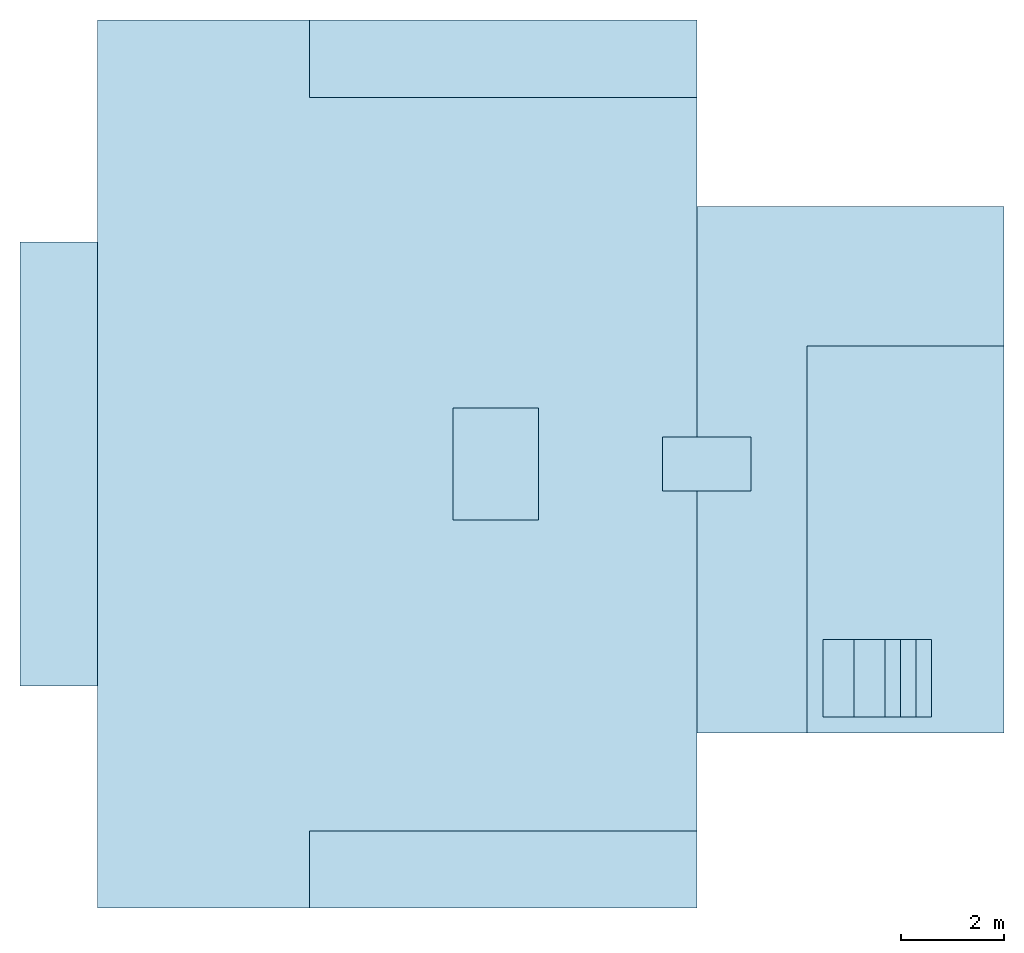
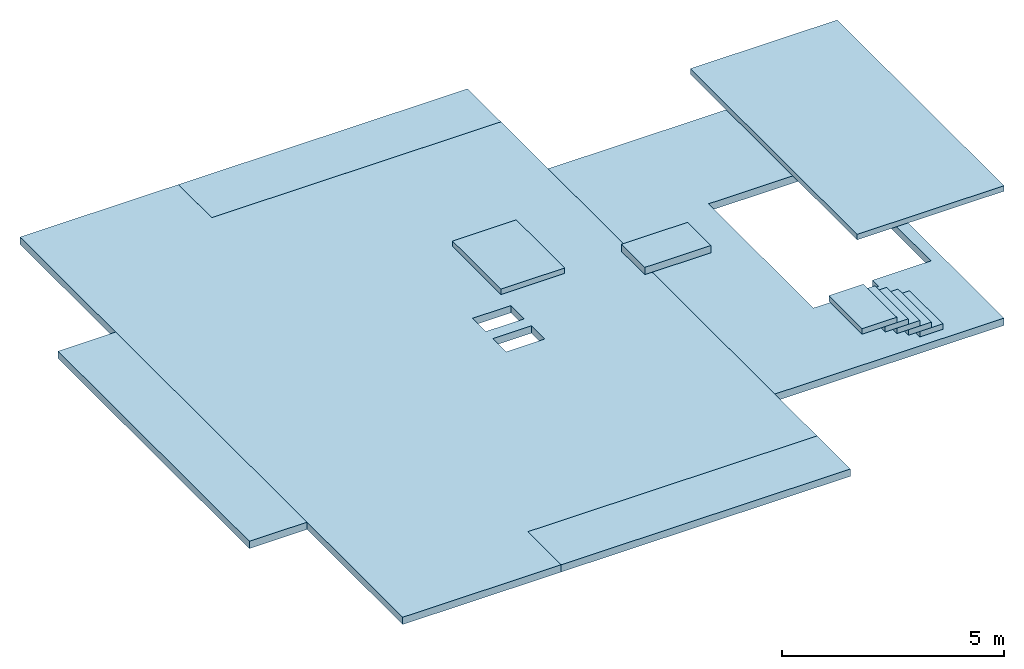
# One storey: 11 slabs, 1 opening.
"""IFC2X3 building model written with IfcOpenShell, lengths in millimetres."""

from ifc_helpers import new_model, entity, si_unit, converted_unit, derived_unit, direction, frame, frame_2d, origin, origin_2d_with_axis, place, context, subcontext, project, spatial, polyline, rectangle, outline, extrude, material, layer, layer_set, layer_usage, type_object, element, save


model = new_model("IFC2X3")

# Units and contexts
model_context = context("Model", 3, precision=0.01, world=origin(), true_north=direction((6.12303176911189e-17, 1.0)))
body_context = subcontext(model_context, "Body", "Model", "MODEL_VIEW")
ifc_project = project(units=[si_unit("LENGTHUNIT", "METRE", prefix="MILLI"), si_unit("AREAUNIT", "SQUARE_METRE"), si_unit("VOLUMEUNIT", "CUBIC_METRE"), converted_unit("PLANEANGLEUNIT", "DEGREE", entity("IfcRatioMeasure", 0.0174532925199433), si_unit("PLANEANGLEUNIT", "RADIAN"), dimensions=[0, 0, 0, 0, 0, 0, 0]), si_unit("MASSUNIT", "GRAM", prefix="KILO"), derived_unit("MASSDENSITYUNIT", [(si_unit("MASSUNIT", "GRAM", prefix="KILO"), 1), (si_unit("LENGTHUNIT", "METRE"), -3)]), si_unit("TIMEUNIT", "SECOND"), si_unit("FREQUENCYUNIT", "HERTZ"), si_unit("THERMODYNAMICTEMPERATUREUNIT", "DEGREE_CELSIUS"), derived_unit("THERMALTRANSMITTANCEUNIT", [(si_unit("MASSUNIT", "GRAM", prefix="KILO"), 1), (si_unit("THERMODYNAMICTEMPERATUREUNIT", "KELVIN"), -1), (si_unit("TIMEUNIT", "SECOND"), -3)]), derived_unit("VOLUMETRICFLOWRATEUNIT", [(si_unit("LENGTHUNIT", "METRE"), 3), (si_unit("TIMEUNIT", "SECOND"), -1)]), si_unit("ELECTRICCURRENTUNIT", "AMPERE"), si_unit("ELECTRICVOLTAGEUNIT", "VOLT"), si_unit("POWERUNIT", "WATT"), si_unit("FORCEUNIT", "NEWTON", prefix="KILO"), si_unit("ILLUMINANCEUNIT", "LUX"), si_unit("LUMINOUSFLUXUNIT", "LUMEN"), si_unit("LUMINOUSINTENSITYUNIT", "CANDELA"), derived_unit("USERDEFINED", [(si_unit("MASSUNIT", "GRAM", prefix="KILO"), -1), (si_unit("LENGTHUNIT", "METRE"), -2), (si_unit("TIMEUNIT", "SECOND"), 3), (si_unit("LUMINOUSFLUXUNIT", "LUMEN"), 1)]), derived_unit("LINEARVELOCITYUNIT", [(si_unit("LENGTHUNIT", "METRE"), 1), (si_unit("TIMEUNIT", "SECOND"), -1)]), si_unit("PRESSUREUNIT", "PASCAL"), derived_unit("USERDEFINED", [(si_unit("LENGTHUNIT", "METRE"), -2), (si_unit("MASSUNIT", "GRAM", prefix="KILO"), 1), (si_unit("TIMEUNIT", "SECOND"), -2)])], contexts=[model_context])

# Site, building, storey
site_placement = place(None, origin())
site = spatial("IfcSite", under=ifc_project, at=site_placement, CompositionType="ELEMENT")
building_placement = place(site_placement, origin())
building = spatial("IfcBuilding", under=site, at=building_placement, CompositionType="ELEMENT")
storey_placement = place(building_placement, frame((0.0, 0.0, 16000.0)))
storey = spatial("IfcBuildingStorey", under=building, at=storey_placement, Name="04 Roof", CompositionType="ELEMENT", Elevation=16000.0)

# Slabs
ifc_material = material(Name="02_C40/50")
ifc_layer_1 = layer(ifc_material, 200.0)
ifc_layer_set_1 = layer_set([ifc_layer_1], Name="Floor:200mm")
ifc_layer_usage_1 = layer_usage(ifc_layer_set_1, "AXIS3", "POSITIVE", 0.0)
slab_type_1 = type_object("IfcSlabType", Name="Floor:200mm", PredefinedType="FLOOR", material=ifc_layer_set_1)
slab_1_placement = place(storey_placement, origin())
element("IfcSlab", 1, at=slab_1_placement, inside=storey, type_object=slab_type_1, material=ifc_layer_usage_1, Name="Floor:200mm", ObjectType="Floor:200mm", PredefinedType="FLOOR", context=body_context, shape_type="SweptSolid", body=[
    extrude(outline(polyline([(-8424.63257743351, -4418.82352941176), (-7984.63257743348, -4418.82352941176), (-4114.6325774335, -4418.82352941177), (-3674.63257743349, -4418.82352941177), (4505.36742256648, -4418.82352941178), (4635.3674225665, -4418.82352941178), (8815.36742256649, -4418.82352941179), (8815.36742256649, -3978.82352941179), (8815.36742256649, -298.82352941177), (7315.3674225665, -298.82352941177), (7315.3674225665, 7221.17647058823), (5414.95202802297, 7221.17647058823), (-4360.04797197706, 7221.17647058825), (-4800.04797197706, 7221.17647058825), (-6924.63257743345, 7221.17647058825), (-6924.63257743349, -298.823529411727), (-8424.63257743349, -298.823529411718), (-8424.63257743351, -4418.82352941176)]), holes=[polyline([(355.367422566508, 3811.17647058826), (955.367422566518, 3811.17647058826), (955.367422566518, 2811.17647058824), (355.367422566508, 2811.17647058824), (355.367422566508, 3811.17647058826)]), polyline([(-564.632577433474, 3811.17647058825), (35.367422566537, 3811.17647058825), (35.367422566537, 2811.17647058825), (-564.632577433474, 2811.17647058825), (-564.632577433474, 3811.17647058825)])]), frame((21592.3136002636, -68635.8721625734, -340.0), z_axis=(0.0, 0.0, 1.0), x_axis=(0.0, -1.0, 0.0)), (0.0, 0.0, 1.0), 200.0),
])
ifc_layer_usage_2 = layer_usage(ifc_layer_set_1, "AXIS3", "POSITIVE", 0.0)
slab_type_2 = type_object("IfcSlabType", Name="Floor:200mm", PredefinedType="FLOOR", material=ifc_layer_set_1)
slab_2_placement = place(storey_placement, origin())
element("IfcSlab", 2, at=slab_2_placement, inside=storey, type_object=slab_type_2, material=ifc_layer_usage_2, Name="Floor:200mm", ObjectType="Floor:200mm", PredefinedType="FLOOR", context=body_context, shape_type="SweptSolid", body=[
    extrude(rectangle(XDim=1500.00000000003, YDim=8619.99999999999, at=frame_2d((60.7142857142665, -552.857142857147), x_axis=(1.0, 0.0))), frame((16362.7757851375, -68278.3824422828, -340.0)), (0.0, 0.0, 1.0), 200.0),
    extrude(rectangle(XDim=1499.99999999999, YDim=7520.0, at=frame_2d((73.3333333333339, -1180.0), x_axis=(1.0, 0.0))), frame((26233.4900708518, -76627.9062518066, -340.0), z_axis=(0.0, 0.0, 1.0), x_axis=(0.0, -1.0, 0.0)), (0.0, 0.0, 1.0), 200.0),
    extrude(rectangle(XDim=7520.0, YDim=1500.0, at=frame_2d((-663.999999999995, -149.999999999996), x_axis=(1.0, 0.0))), frame((25717.4900708518, -60811.23958514, -340.0)), (0.0, 0.0, 1.0), 200.0),
])

# Slab, opening
ifc_layer_usage_3 = layer_usage(ifc_layer_set_1, "AXIS3", "POSITIVE", 0.0)
slab_type_3 = type_object("IfcSlabType", Name="Floor:200mm", PredefinedType="FLOOR", material=ifc_layer_set_1)
slab_3_placement = place(storey_placement, frame((28813.4900708518, -74050.8241905964, -340.0)))
slab_3 = element("IfcSlab", 3, at=slab_3_placement, inside=storey, type_object=slab_type_3, material=ifc_layer_usage_3, Name="Floor:200mm", ObjectType="Floor:200mm", PredefinedType="FLOOR", context=body_context, shape_type="SweptSolid", body=[
    extrude(rectangle(XDim=10215.0, YDim=5960.0, at=frame_2d((0.0, 0.0), x_axis=(0.0, -1.0))), frame((2980.0, 5107.50000000002, 200.0), z_axis=(0.0, 0.0, -1.0), x_axis=(-1.0, 0.0, 0.0)), (0.0, 0.0, 1.0), 200.0),
])
opening_placement = place(slab_3_placement, frame((4078.06051010693, 4158.33333333338, 200.0)))
element("IfcOpeningElement", 4, at=opening_placement, cuts=slab_3, Name="Floor:200mm:2", ObjectType="Opening", context=body_context, shape_type="SweptSolid", body=[
    extrude(outline(polyline([(-56.1210202139049, -1668.33333333331), (1638.06051010692, -1668.33333333331), (1638.06051010692, 3056.66666666665), (-1581.93948989304, 3056.66666666665), (-1581.93948989304, -1388.33333333332), (-56.1210202139049, -1388.33333333332), (-56.1210202139049, -1668.33333333331)])), frame((0.0, 0.0, 0.0), z_axis=(0.0, 0.0, -1.0), x_axis=(-1.0, 0.0, 0.0)), (0.0, 0.0, 1.0), 200.0),
])

# Slabs
ifc_layer_2 = layer(ifc_material, 150.0)
ifc_layer_set_2 = layer_set([ifc_layer_2], Name="Floor:150mm")
ifc_layer_usage_4 = layer_usage(ifc_layer_set_2, "AXIS3", "POSITIVE", 0.0)
slab_type_4 = type_object("IfcSlabType", Name="Floor:150mm", PredefinedType="FLOOR", material=ifc_layer_set_2)
slab_4_placement = place(storey_placement, origin())
element("IfcSlab", 5, at=slab_4_placement, inside=storey, type_object=slab_type_4, material=ifc_layer_usage_4, Name="Floor:150mm", ObjectType="Floor:150mm", PredefinedType="FLOOR", context=body_context, shape_type="SweptSolid", body=[
    extrude(rectangle(XDim=2179.99999999998, YDim=1660.0, at=frame_2d((-4.32009983342141e-12, 0.0), x_axis=(1.0, 0.0))), frame((24903.4900708518, -68831.2395851399, 1900.0), z_axis=(0.0, 0.0, -1.0), x_axis=(0.0, 1.0, 0.0)), (0.0, 0.0, 1.0), 150.000000000001),
])
ifc_layer_usage_5 = layer_usage(ifc_layer_set_2, "AXIS3", "POSITIVE", 0.0)
slab_type_5 = type_object("IfcSlabType", Name="Floor:150mm", PredefinedType="FLOOR", material=ifc_layer_set_2)
slab_5_placement = place(storey_placement, origin())
element("IfcSlab", 6, at=slab_5_placement, inside=storey, type_object=slab_type_5, material=ifc_layer_usage_5, Name="Floor:150mm", ObjectType="Floor:150mm", PredefinedType="FLOOR", context=body_context, shape_type="SweptSolid", body=[
    extrude(rectangle(XDim=7515.00000000004, YDim=3820.00000000002, at=origin_2d_with_axis()), frame((32863.4900708518, -70293.3241905964, 3500.0), z_axis=(0.0, 0.0, -1.0), x_axis=(0.0, 1.0, 0.0)), (0.0, 0.0, 1.0), 150.000000000001),
])
ifc_layer_usage_6 = layer_usage(ifc_layer_set_1, "AXIS3", "POSITIVE", 0.0)
slab_type_6 = type_object("IfcSlabType", Name="Floor:200mm", PredefinedType="FLOOR", material=ifc_layer_set_1)
slab_6_placement = place(storey_placement, origin())
element("IfcSlab", 7, at=slab_6_placement, inside=storey, type_object=slab_type_6, material=ifc_layer_usage_6, Name="Floor:200mm", ObjectType="Floor:200mm", PredefinedType="FLOOR", context=body_context, shape_type="SweptSolid", body=[
    extrude(rectangle(XDim=1050.0, YDim=1720.44467944483, at=frame_2d((0.0, 2.1600499167107e-12), x_axis=(1.0, 0.0))), frame((29002.2340420179, -68831.2395851399, 730.0), z_axis=(0.0, 0.0, -1.0), x_axis=(0.0, 1.0, 0.0)), (0.0, 0.0, 1.0), 200.0),
])
ifc_layer_usage_7 = layer_usage(ifc_layer_set_2, "AXIS3", "POSITIVE", 0.0)
slab_type_7 = type_object("IfcSlabType", Name="Floor:150mm", PredefinedType="FLOOR", material=ifc_layer_set_2)
slab_7_placement = place(storey_placement, origin())
element("IfcSlab", 8, at=slab_7_placement, inside=storey, type_object=slab_type_7, material=ifc_layer_usage_7, Name="Floor:150mm", ObjectType="Floor:150mm", PredefinedType="FLOOR", context=body_context, shape_type="SweptSolid", body=[
    extrude(rectangle(XDim=1500.0, YDim=599.999999999998, at=frame_2d((-4.32009983342141e-12, -2.1600499167107e-12), x_axis=(1.0, 0.0))), frame((33063.4900708518, -72990.8241905963, 10.0), z_axis=(0.0, 0.0, -1.0), x_axis=(0.0, 1.0, 0.0)), (0.0, 0.0, 1.0), 150.000000000001),
])
ifc_layer_usage_8 = layer_usage(ifc_layer_set_2, "AXIS3", "POSITIVE", 0.0)
slab_type_8 = type_object("IfcSlabType", Name="Floor:150mm", PredefinedType="FLOOR", material=ifc_layer_set_2)
slab_8_placement = place(storey_placement, origin())
element("IfcSlab", 9, at=slab_8_placement, inside=storey, type_object=slab_type_8, material=ifc_layer_usage_8, Name="Floor:150mm", ObjectType="Floor:150mm", PredefinedType="FLOOR", context=body_context, shape_type="SweptSolid", body=[
    extrude(rectangle(XDim=1500.0, YDim=600.000000000002, at=frame_2d((-4.32009983342141e-12, 0.0), x_axis=(1.0, 0.0))), frame((32763.4900708518, -72990.8241905963, 160.0), z_axis=(0.0, 0.0, -1.0), x_axis=(0.0, 1.0, 0.0)), (0.0, 0.0, 1.0), 150.000000000001),
])
ifc_layer_usage_9 = layer_usage(ifc_layer_set_2, "AXIS3", "POSITIVE", 0.0)
slab_type_9 = type_object("IfcSlabType", Name="Floor:150mm", PredefinedType="FLOOR", material=ifc_layer_set_2)
slab_9_placement = place(storey_placement, origin())
element("IfcSlab", 10, at=slab_9_placement, inside=storey, type_object=slab_type_9, material=ifc_layer_usage_9, Name="Floor:150mm", ObjectType="Floor:150mm", PredefinedType="FLOOR", context=body_context, shape_type="SweptSolid", body=[
    extrude(rectangle(XDim=1500.0, YDim=600.000000000002, at=frame_2d((-4.32009983342141e-12, 0.0), x_axis=(1.0, 0.0))), frame((32463.4900708518, -72990.8241905963, 310.0), z_axis=(0.0, 0.0, -1.0), x_axis=(0.0, 1.0, 0.0)), (0.0, 0.0, 1.0), 150.000000000001),
])
ifc_layer_usage_10 = layer_usage(ifc_layer_set_2, "AXIS3", "POSITIVE", 0.0)
slab_type_10 = type_object("IfcSlabType", Name="Floor:150mm", PredefinedType="FLOOR", material=ifc_layer_set_2)
slab_10_placement = place(storey_placement, origin())
element("IfcSlab", 11, at=slab_10_placement, inside=storey, type_object=slab_type_10, material=ifc_layer_usage_10, Name="Floor:150mm", ObjectType="Floor:150mm", PredefinedType="FLOOR", context=body_context, shape_type="SweptSolid", body=[
    extrude(rectangle(XDim=1500.0, YDim=600.000000000002, at=frame_2d((-4.32009983342141e-12, 0.0), x_axis=(1.0, 0.0))), frame((32163.4900708518, -72990.8241905963, 460.0), z_axis=(0.0, 0.0, -1.0), x_axis=(0.0, 1.0, 0.0)), (0.0, 0.0, 1.0), 150.000000000001),
])
ifc_layer_usage_11 = layer_usage(ifc_layer_set_2, "AXIS3", "POSITIVE", 0.0)
slab_type_11 = type_object("IfcSlabType", Name="Floor:150mm", PredefinedType="FLOOR", material=ifc_layer_set_2)
slab_11_placement = place(storey_placement, origin())
element("IfcSlab", 12, at=slab_11_placement, inside=storey, type_object=slab_type_11, material=ifc_layer_usage_11, Name="Floor:150mm", ObjectType="Floor:150mm", PredefinedType="FLOOR", context=body_context, shape_type="SweptSolid", body=[
    extrude(rectangle(XDim=1500.0, YDim=899.999999999999, at=frame_2d((-4.32009983342141e-12, -2.1600499167107e-12), x_axis=(1.0, 0.0))), frame((31713.4900708518, -72990.8241905963, 610.0), z_axis=(0.0, 0.0, -1.0), x_axis=(0.0, 1.0, 0.0)), (0.0, 0.0, 1.0), 150.000000000001),
])

save(model, "model.ifc")
